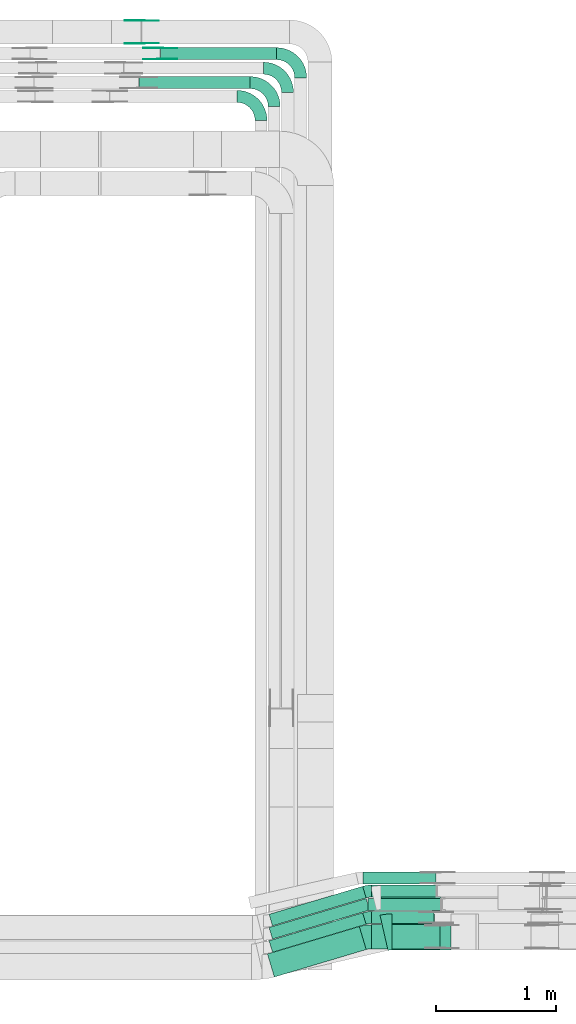
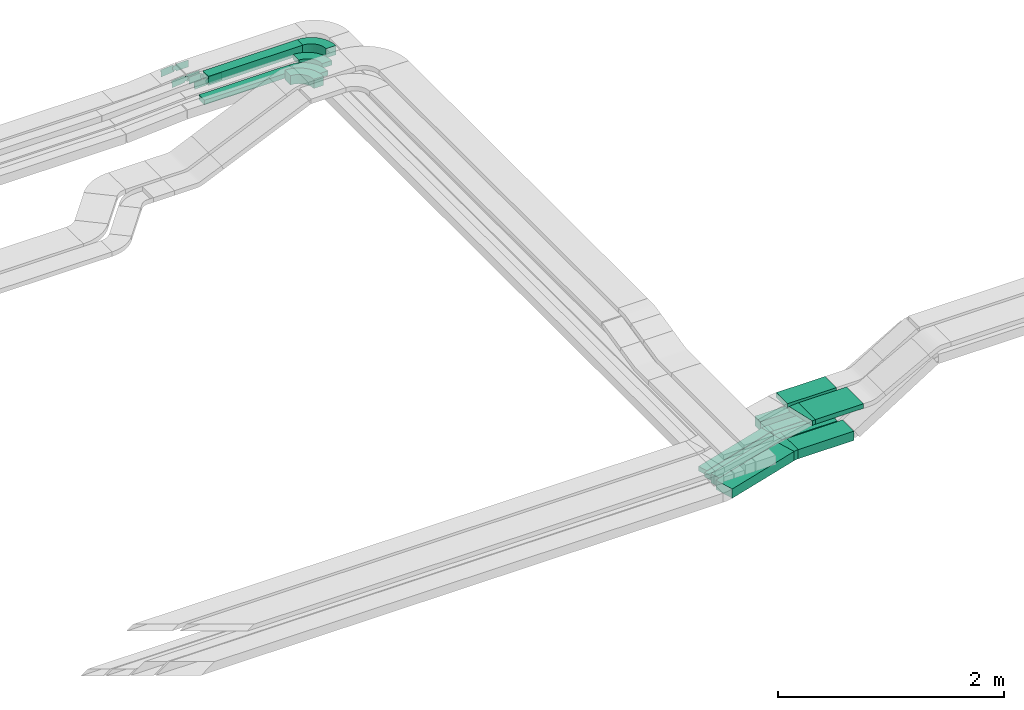
# One storey, part 24 of 31: 16 flow fittings, 13 flow segments.
"""IFC2X3 building model written with IfcOpenShell, lengths in millimetres."""

from ifc_helpers import new_model, entity, si_unit, converted_unit, derived_unit, direction, frame, frame_2d, origin, origin_2d_with_axis, place, context, subcontext, project, spatial, polyline, circle_curve, parameter, trimmed, segment, composite_curve, rectangle, outline, extrude, source, transform, mapped, material, type_object, type_shapes, element, save


model = new_model("IFC2X3")

# Units and contexts
model_context = context("Model", 3, precision=0.01, world=origin(), true_north=direction((6.12303176911189e-17, 1.0)))
body_context = subcontext(model_context, "Body", "Model", "MODEL_VIEW")
ifc_project = project(units=[si_unit("LENGTHUNIT", "METRE", prefix="MILLI"), si_unit("AREAUNIT", "SQUARE_METRE"), si_unit("VOLUMEUNIT", "CUBIC_METRE"), converted_unit("PLANEANGLEUNIT", "DEGREE", entity("IfcRatioMeasure", 0.0174532925199433), si_unit("PLANEANGLEUNIT", "RADIAN"), dimensions=[0, 0, 0, 0, 0, 0, 0]), si_unit("MASSUNIT", "GRAM", prefix="KILO"), derived_unit("MASSDENSITYUNIT", [(si_unit("MASSUNIT", "GRAM", prefix="KILO"), 1), (si_unit("LENGTHUNIT", "METRE"), -3)]), derived_unit("MOMENTOFINERTIAUNIT", [(si_unit("LENGTHUNIT", "METRE"), 4)]), si_unit("TIMEUNIT", "SECOND"), si_unit("FREQUENCYUNIT", "HERTZ"), si_unit("THERMODYNAMICTEMPERATUREUNIT", "DEGREE_CELSIUS"), derived_unit("THERMALTRANSMITTANCEUNIT", [(si_unit("MASSUNIT", "GRAM", prefix="KILO"), 1), (si_unit("THERMODYNAMICTEMPERATUREUNIT", "KELVIN"), -1), (si_unit("TIMEUNIT", "SECOND"), -3)]), derived_unit("VOLUMETRICFLOWRATEUNIT", [(si_unit("LENGTHUNIT", "METRE"), 3), (si_unit("TIMEUNIT", "SECOND"), -1)]), derived_unit("MASSFLOWRATEUNIT", [(si_unit("MASSUNIT", "GRAM", prefix="KILO"), 1), (si_unit("TIMEUNIT", "SECOND"), -1)]), derived_unit("ROTATIONALFREQUENCYUNIT", [(si_unit("TIMEUNIT", "SECOND"), -1)]), si_unit("ELECTRICCURRENTUNIT", "AMPERE"), si_unit("ELECTRICVOLTAGEUNIT", "VOLT"), si_unit("POWERUNIT", "WATT"), si_unit("FORCEUNIT", "NEWTON", prefix="KILO"), si_unit("ILLUMINANCEUNIT", "LUX"), si_unit("LUMINOUSFLUXUNIT", "LUMEN"), si_unit("LUMINOUSINTENSITYUNIT", "CANDELA"), derived_unit("USERDEFINED", [(si_unit("MASSUNIT", "GRAM", prefix="KILO"), -1), (si_unit("LENGTHUNIT", "METRE"), -2), (si_unit("TIMEUNIT", "SECOND"), 3), (si_unit("LUMINOUSFLUXUNIT", "LUMEN"), 1)]), derived_unit("LINEARVELOCITYUNIT", [(si_unit("LENGTHUNIT", "METRE"), 1), (si_unit("TIMEUNIT", "SECOND"), -1)]), si_unit("PRESSUREUNIT", "PASCAL"), derived_unit("USERDEFINED", [(si_unit("LENGTHUNIT", "METRE"), -2), (si_unit("MASSUNIT", "GRAM", prefix="KILO"), 1), (si_unit("TIMEUNIT", "SECOND"), -2)]), derived_unit("LINEARFORCEUNIT", [(si_unit("MASSUNIT", "GRAM", prefix="KILO"), 1), (si_unit("LENGTHUNIT", "METRE"), 1), (si_unit("TIMEUNIT", "SECOND"), -2), (si_unit("LENGTHUNIT", "METRE"), -1)]), derived_unit("PLANARFORCEUNIT", [(si_unit("MASSUNIT", "GRAM", prefix="KILO"), 1), (si_unit("LENGTHUNIT", "METRE"), 1), (si_unit("TIMEUNIT", "SECOND"), -2), (si_unit("LENGTHUNIT", "METRE"), -2)])], contexts=[model_context])

# Site, building, storey
site_placement = place(None, frame((0.0, -0.00077364408347762, 0.0)))
site = spatial("IfcSite", under=ifc_project, at=site_placement, CompositionType="ELEMENT")
building_placement = place(site_placement, origin())
building = spatial("IfcBuilding", under=site, at=building_placement, CompositionType="ELEMENT")
storey_placement = place(building_placement, frame((0.0, 0.0, 15900.0)))
storey = spatial("IfcBuildingStorey", under=building, at=storey_placement, CompositionType="ELEMENT", Elevation=15900.0)

# Flow segments
cable_carrier_segment_type = type_object("IfcCableCarrierSegmentType", PredefinedType="CABLETRAYSEGMENT")
flow_segment_1_placement = place(storey_placement, frame((60243.1382371041, 8665.72641574027, 2495.02366929601)))
element("IfcFlowSegment", 1, at=flow_segment_1_placement, inside=storey, type_object=cable_carrier_segment_type, context=body_context, shape_type="SweptSolid", body=[
    extrude(rectangle(XDim=812.342114695417, YDim=100.000000000006, at=frame_2d((4.14956957683899e-12, -1.23634436022257e-12), x_axis=(1.0, 0.0))), frame((403.475378060986, 164.239638386226, 0.0), z_axis=(0.0, 0.0, 1.0), x_axis=(-0.95810498938811, -0.286417229421712, 0.0)), (0.0, 0.0, 1.0), 50.0000000000016),
])
flow_segment_2_placement = place(storey_placement, frame((60243.1382371041, 8555.72641574028, 2495.0546523344)))
element("IfcFlowSegment", 2, at=flow_segment_2_placement, inside=storey, type_object=cable_carrier_segment_type, context=body_context, shape_type="SweptSolid", body=[
    extrude(rectangle(XDim=842.596647110519, YDim=100.000000000006, at=frame_2d((4.17799128626939e-12, -1.24344978758018e-12), x_axis=(1.0, 0.0))), frame((417.96888729023, 168.572348062131, 0.0), z_axis=(0.0, 0.0, 1.0), x_axis=(0.9581049893881, 0.286417229421747, 0.0)), (0.0, 0.0, 1.0), 50.0000000000016),
])
flow_segment_3_placement = place(storey_placement, frame((60243.1382371041, 8445.72641574016, 2500.0)))
element("IfcFlowSegment", 3, at=flow_segment_3_placement, inside=storey, type_object=cable_carrier_segment_type, context=body_context, shape_type="SweptSolid", body=[
    extrude(rectangle(XDim=812.342114695347, YDim=100.000000000004, at=frame_2d((1.70530256582424e-13, 5.08038056068472e-13), x_axis=(1.0, 0.0))), frame((403.475378060934, 164.239638386233, 0.0), z_axis=(0.0, 0.0, 1.0), x_axis=(-0.958104989388097, -0.286417229421757, 0.0)), (0.0, 0.0, 1.0), 99.9999999999989),
])
flow_segment_4_placement = place(storey_placement, frame((60229.5481308941, 8239.91591680136, 2500.0)))
element("IfcFlowSegment", 4, at=flow_segment_4_placement, inside=storey, type_object=cable_carrier_segment_type, context=body_context, shape_type="SweptSolid", body=[
    extrude(rectangle(XDim=797.71484848776, YDim=200.000000000007, at=frame_2d((-1.4210854715202e-13, -5.04485342389671e-13), x_axis=(1.0, 0.0))), frame((410.789011164725, 210.050137325046, 0.0), z_axis=(0.0, 0.0, 1.0), x_axis=(0.958104989388095, 0.286417229421762, 0.0)), (0.0, 0.0, 1.0), 99.9999999999989),
])
flow_segment_5_placement = place(storey_placement, frame((61095.0096826287, 8904.9658623951, 2495.02366929601)))
element("IfcFlowSegment", 5, at=flow_segment_5_placement, inside=storey, type_object=cable_carrier_segment_type, context=body_context, shape_type="SweptSolid", body=[
    extrude(rectangle(XDim=534.84490584839, YDim=99.9999999999989, at=frame_2d((-4.32009983342141e-12, -5.40012479177676e-13), x_axis=(1.0, 0.0))), frame((267.422452924191, 50.0, 0.0)), (0.0, 0.0, 1.0), 50.0000000000016),
])
flow_segment_6_placement = place(storey_placement, frame((61064.7551502134, 8794.96586239509, 2500.0)))
element("IfcFlowSegment", 6, at=flow_segment_6_placement, inside=storey, type_object=cable_carrier_segment_type, context=body_context, shape_type="SweptSolid", body=[
    extrude(rectangle(XDim=603.13391952185, YDim=100.000000000001, at=frame_2d((0.0, -5.43565192856477e-13), x_axis=(1.0, 0.0))), frame((301.566959760925, 50.0, 0.0), z_axis=(0.0, 0.0, 1.0), x_axis=(-1.0, 0.0, 0.0)), (0.0, 0.0, 1.0), 50.0000000000016),
])
flow_segment_7_placement = place(storey_placement, frame((61095.0096826286, 8684.96586239501, 2500.0)))
element("IfcFlowSegment", 7, at=flow_segment_7_placement, inside=storey, type_object=cable_carrier_segment_type, context=body_context, shape_type="SweptSolid", body=[
    extrude(rectangle(XDim=521.540062553163, YDim=99.9999999999989, at=frame_2d((0.0, 1.08357767203415e-12), x_axis=(1.0, 0.0))), frame((260.770031276573, 50.0, 0.0)), (0.0, 0.0, 1.0), 99.9999999999989),
])
flow_segment_8_placement = place(storey_placement, frame((61096.0468426262, 8474.96586239501, 2500.0)))
element("IfcFlowSegment", 8, at=flow_segment_8_placement, inside=storey, type_object=cable_carrier_segment_type, context=body_context, shape_type="SweptSolid", body=[
    extrude(rectangle(XDim=569.341253253551, YDim=200.0, at=frame_2d((4.32009983342141e-12, 0.0), x_axis=(1.0, 0.0))), frame((284.67062662678, 100.0, 0.0), z_axis=(0.0, 0.0, 1.0), x_axis=(-1.0, 0.0, 0.0)), (0.0, 0.0, 1.0), 99.9999999999989),
])
flow_segment_9_placement = place(storey_placement, frame((61174.2051072231, 8800.14842319197, 2820.0)))
element("IfcFlowSegment", 9, at=flow_segment_9_placement, inside=storey, type_object=cable_carrier_segment_type, context=body_context, shape_type="SweptSolid", body=[
    extrude(rectangle(XDim=499.125355174538, YDim=200.0, at=origin_2d_with_axis()), frame((249.562677587277, 100.0, 0.0)), (0.0, 0.0, 1.0), 50.0000000000016),
])
flow_segment_10_placement = place(storey_placement, frame((61267.5917209421, 8465.14842319196, 2820.0)))
element("IfcFlowSegment", 10, at=flow_segment_10_placement, inside=storey, type_object=cable_carrier_segment_type, context=body_context, shape_type="SweptSolid", body=[
    extrude(rectangle(XDim=489.342035058011, YDim=300.000000000001, at=frame_2d((4.33431068813661e-12, 5.40012479177676e-13), x_axis=(1.0, 0.0))), frame((244.67101752901, 150.0, 0.0)), (0.0, 0.0, 1.0), 50.0000000000016),
])
flow_segment_11_placement = place(storey_placement, frame((59341.7533007702, 15869.9939089946, 2660.0)))
element("IfcFlowSegment", 11, at=flow_segment_11_placement, inside=storey, type_object=cable_carrier_segment_type, context=body_context, shape_type="SweptSolid", body=[
    extrude(rectangle(XDim=963.323442098033, YDim=99.9999999999989, at=frame_2d((-4.32009983342141e-12, 1.08357767203415e-12), x_axis=(1.0, 0.0))), frame((481.661721049012, 50.0, 0.0), z_axis=(0.0, 0.0, 1.0), x_axis=(-1.0, 0.0, 0.0)), (0.0, 0.0, 1.0), 99.9999999999989),
])
flow_segment_12_placement = place(storey_placement, frame((59162.3763917152, 15629.4580000518, 2660.19015606754)))
element("IfcFlowSegment", 12, at=flow_segment_12_placement, inside=storey, type_object=cable_carrier_segment_type, context=body_context, shape_type="SweptSolid", body=[
    extrude(rectangle(XDim=922.700351153026, YDim=99.9999999999989, at=frame_2d((0.0, 1.08357767203415e-12), x_axis=(1.0, 0.0))), frame((461.350175576513, 50.0, 0.0), z_axis=(0.0, 0.0, 1.0), x_axis=(-1.0, 0.0, 0.0)), (0.0, 0.0, 1.0), 50.0000000000016),
])
flow_segment_13_placement = place(storey_placement, frame((61022.4340197536, 9014.96586239511, 2500.0)))
element("IfcFlowSegment", 13, at=flow_segment_13_placement, inside=storey, type_object=cable_carrier_segment_type, context=body_context, shape_type="SweptSolid", body=[
    extrude(rectangle(XDim=607.951662645595, YDim=99.9999999999989, at=frame_2d((-4.32009983342141e-12, -5.40012479177676e-13), x_axis=(1.0, 0.0))), frame((303.975831322811, 50.0, 0.0)), (0.0, 0.0, 1.0), 99.9999999999989),
])

# Flow fittings
ifc_material_1 = material()
cable_carrier_fitting_type_1 = type_object("IfcCableCarrierFittingType", Name="470_DKC_S5_Variable Angle Elbow 0-45:-", PredefinedType="NOTDEFINED", material=ifc_material_1)
shared_shape_1 = source(origin(), body_context, "Body", "SweptSolid", [
    extrude(outline(composite_curve([segment(polyline([(-29.6312491895192, -54.2611053685444), (-28.6312491895179, -54.2611053685444)]), True, "CONTINUOUS"), segment(trimmed(circle_curve(frame_2d((-28.6312491895183, 195.738894631455), x_axis=(0.0, -1.0)), 250.0), [parameter(0.0)], [parameter(16.6435818354741)], True, "PARAMETER"), True, "CONTINUOUS"), segment(polyline([(42.9730581659098, -43.7873527155719), (43.931163155298, -43.5009354861501)]), True, "CONTINUOUS"), segment(polyline([(43.931163155298, -43.5009354861502), (15.2894402131266, 52.3095634526607)]), True, "CONTINUOUS"), segment(polyline([(15.2894402131266, 52.3095634526607), (14.3313352237385, 52.023146223239)]), True, "CONTINUOUS"), segment(trimmed(circle_curve(frame_2d((-28.6312491895183, 195.738894631455), x_axis=(0.0, -1.0)), 150.0), [parameter(0.0)], [parameter(16.6435818354741)], True, "PARAMETER"), False, "CONTINUOUS"), segment(polyline([(-28.6312491895179, 45.7388946314555), (-29.6312491895192, 45.7388946314555)]), True, "CONTINUOUS"), segment(polyline([(-29.6312491895192, 45.7388946314555), (-29.6312491895192, -54.2611053685444)]), True, "CONTINUOUS")], self_intersect=False)), frame((-0.623283225632705, 4.26110536853636, -25.0)), (0.0, 0.0, 1.0), 50.0000000000001),
])
type_shapes(cable_carrier_fitting_type_1, [shared_shape_1])
flow_fitting_1_placement = place(storey_placement, frame((61064.7551502135, 8954.9658623951, 2520.02366929601), z_axis=(0.0, 0.0, 1.0), x_axis=(-1.0, 0.0, 0.0)))
element("IfcFlowFitting", 14, at=flow_fitting_1_placement, inside=storey, type_object=cable_carrier_fitting_type_1, material=ifc_material_1, Name="470_DKC_S5_Variable Angle Elbow 0-45:-", ObjectType="470_DKC_S5_Variable Angle Elbow 0-45:-", context=body_context, shape_type="MappedRepresentation", body=[
    mapped(shared_shape_1, transform((0.0, 0.0, 0.0), scale=1.0)),
])
cable_carrier_fitting_type_2 = type_object("IfcCableCarrierFittingType", Name="470_DKC_S5_Variable Angle Elbow 0-45:-", PredefinedType="NOTDEFINED", material=ifc_material_1)
shared_shape_2 = source(origin(), body_context, "Body", "SweptSolid", [
    extrude(outline(composite_curve([segment(polyline([(-29.631249189521, -54.2611053685453), (-28.6312491895196, -54.2611053685453)]), True, "CONTINUOUS"), segment(trimmed(circle_curve(frame_2d((-28.6312491895222, 195.738894631454), x_axis=(0.0, -1.0)), 250.0), [parameter(0.0)], [parameter(16.6435818354755)], True, "PARAMETER"), True, "CONTINUOUS"), segment(polyline([(42.9730581659135, -43.7873527155705), (43.9311631553015, -43.5009354861488)]), True, "CONTINUOUS"), segment(polyline([(43.9311631553016, -43.5009354861488), (15.2894402131274, 52.3095634526612)]), True, "CONTINUOUS"), segment(polyline([(15.2894402131274, 52.3095634526612), (14.3313352237392, 52.0231462232395)]), True, "CONTINUOUS"), segment(trimmed(circle_curve(frame_2d((-28.6312491895222, 195.738894631454), x_axis=(0.0, -1.0)), 150.0), [parameter(0.0)], [parameter(16.6435818354755)], True, "PARAMETER"), False, "CONTINUOUS"), segment(polyline([(-28.6312491895205, 45.7388946314545), (-29.6312491895218, 45.7388946314545)]), True, "CONTINUOUS"), segment(polyline([(-29.6312491895218, 45.7388946314545), (-29.631249189521, -54.2611053685453)]), True, "CONTINUOUS")], self_intersect=False)), frame((-0.623283225632853, 4.26110536853704, -50.0)), (0.0, 0.0, 1.0), 100.0),
])
type_shapes(cable_carrier_fitting_type_2, [shared_shape_2])
flow_fitting_2_placement = place(storey_placement, frame((61064.7551502134, 8734.96586239502, 2550.0), z_axis=(0.0, 0.0, 1.0), x_axis=(-1.0, 0.0, 0.0)))
element("IfcFlowFitting", 15, at=flow_fitting_2_placement, inside=storey, type_object=cable_carrier_fitting_type_2, material=ifc_material_1, Name="470_DKC_S5_Variable Angle Elbow 0-45:-", ObjectType="470_DKC_S5_Variable Angle Elbow 0-45:-", context=body_context, shape_type="MappedRepresentation", body=[
    mapped(shared_shape_2, transform((0.0, 0.0, 0.0), scale=1.0)),
])
cable_carrier_fitting_type_3 = type_object("IfcCableCarrierFittingType", Name="470_DKC_S5_Variable Angle Elbow 0-45:-", PredefinedType="NOTDEFINED", material=ifc_material_1)
shared_shape_3 = source(origin(), body_context, "Body", "SweptSolid", [
    extrude(outline(composite_curve([segment(polyline([(-36.7916799250648, -105.308480633842), (-35.7916799250634, -105.308480633842)]), True, "CONTINUOUS"), segment(trimmed(circle_curve(frame_2d((-35.791679925064, 244.691519366157), x_axis=(0.0, -1.0)), 350.0), [parameter(0.0)], [parameter(16.6435818354755)], True, "PARAMETER"), True, "CONTINUOUS"), segment(polyline([(64.4543503725433, -90.6452269196786), (65.4124553619312, -90.3588096902569)]), True, "CONTINUOUS"), segment(polyline([(65.4124553619312, -90.3588096902569), (8.12900947758453, 101.262188187364)]), True, "CONTINUOUS"), segment(polyline([(8.12900947758453, 101.262188187364), (7.17090448819626, 100.975770957942)]), True, "CONTINUOUS"), segment(trimmed(circle_curve(frame_2d((-35.791679925064, 244.691519366157), x_axis=(0.0, -1.0)), 150.0), [parameter(0.0)], [parameter(16.6435818354755)], True, "PARAMETER"), False, "CONTINUOUS"), segment(polyline([(-35.7916799250634, 94.6915193661574), (-36.7916799250648, 94.6915193661574)]), True, "CONTINUOUS"), segment(polyline([(-36.7916799250648, 94.6915193661574), (-36.7916799250648, -105.308480633842)]), True, "CONTINUOUS")], self_intersect=False)), frame((-0.776485593880177, 5.30848063383446, -50.0)), (0.0, 0.0, 1.0), 100.0),
])
type_shapes(cable_carrier_fitting_type_3, [shared_shape_3])
flow_fitting_3_placement = place(storey_placement, frame((61058.4786771072, 8574.96586239503, 2550.0), z_axis=(0.0, 0.0, 1.0), x_axis=(-1.0, 0.0, 0.0)))
element("IfcFlowFitting", 16, at=flow_fitting_3_placement, inside=storey, type_object=cable_carrier_fitting_type_3, material=ifc_material_1, Name="470_DKC_S5_Variable Angle Elbow 0-45:-", ObjectType="470_DKC_S5_Variable Angle Elbow 0-45:-", context=body_context, shape_type="MappedRepresentation", body=[
    mapped(shared_shape_3, transform((0.0, 0.0, 0.0), scale=1.0)),
])
cable_carrier_fitting_type_4 = type_object("IfcCableCarrierFittingType", Name="470_DKC_S5_Variable Angle Elbow 0-45:-", PredefinedType="NOTDEFINED", material=ifc_material_1)
shared_shape_4 = source(origin(), body_context, "Body", "SweptSolid", [
    extrude(outline(composite_curve([segment(polyline([(-34.2439370818879, -153.787077593141), (-33.2439370818863, -153.787077593141)]), True, "CONTINUOUS"), segment(trimmed(circle_curve(frame_2d((-33.2439370818946, 296.212922406859), x_axis=(0.0, -1.0)), 450.0), [parameter(0.0)], [parameter(12.8070045345911)], True, "PARAMETER"), True, "CONTINUOUS"), segment(polyline([(66.5065324671094, -142.5920955963), (67.4816547293384, -142.370427886191)]), True, "CONTINUOUS"), segment(polyline([(67.4816547293384, -142.370427886191), (0.98134169666951, 150.166250782582)]), True, "CONTINUOUS"), segment(polyline([(0.981341696669519, 150.166250782582), (0.00621943443999445, 149.944583072473)]), True, "CONTINUOUS"), segment(trimmed(circle_curve(frame_2d((-33.2439370818946, 296.212922406859), x_axis=(0.0, -1.0)), 150.0), [parameter(0.0)], [parameter(12.8070045345911)], True, "PARAMETER"), False, "CONTINUOUS"), segment(polyline([(-33.2439370818914, 146.212922406859), (-34.243937081893, 146.212922406859)]), True, "CONTINUOUS"), segment(polyline([(-34.243937081893, 146.212922406859), (-34.2439370818879, -153.787077593141)]), True, "CONTINUOUS")], self_intersect=False)), frame((-0.425023217098881, 3.78707759313203, -25.0)), (0.0, 0.0, 1.0), 49.9999999999996),
])
type_shapes(cable_carrier_fitting_type_4, [shared_shape_4])
flow_fitting_4_placement = place(storey_placement, frame((61232.9227606431, 8615.14842319198, 2845.0), z_axis=(0.0, 0.0, 1.0), x_axis=(-1.0, 0.0, 0.0)))
element("IfcFlowFitting", 17, at=flow_fitting_4_placement, inside=storey, type_object=cable_carrier_fitting_type_4, material=ifc_material_1, Name="470_DKC_S5_Variable Angle Elbow 0-45:-", ObjectType="470_DKC_S5_Variable Angle Elbow 0-45:-", context=body_context, shape_type="MappedRepresentation", body=[
    mapped(shared_shape_4, transform((0.0, 0.0, 0.0), scale=1.0)),
])
cable_carrier_fitting_type_5 = type_object("IfcCableCarrierFittingType", Name="470_DKC_S5_Variable Angle Elbow 0-45:-", PredefinedType="NOTDEFINED", material=ifc_material_1)
shared_shape_5 = source(origin(), body_context, "Body", "SweptSolid", [
    extrude(outline(composite_curve([segment(polyline([(-100.749999999999, -150.250000000001), (-99.7499999999981, -150.250000000001)]), True, "CONTINUOUS"), segment(trimmed(circle_curve(frame_2d((-99.7500000000006, 99.7499999999987), x_axis=(0.0, -1.0)), 250.0), [parameter(0.0)], [parameter(90.0000000000001)], True, "PARAMETER"), True, "CONTINUOUS"), segment(polyline([(150.249999999999, 99.7500000000013), (150.249999999999, 100.750000000001)]), True, "CONTINUOUS"), segment(polyline([(150.249999999999, 100.750000000001), (50.2499999999992, 100.750000000001)]), True, "CONTINUOUS"), segment(polyline([(50.2499999999992, 100.750000000001), (50.2499999999992, 99.7500000000002)]), True, "CONTINUOUS"), segment(trimmed(circle_curve(frame_2d((-99.7500000000006, 99.7499999999987), x_axis=(0.0, -1.0)), 150.0), [parameter(0.0)], [parameter(90.0000000000001)], True, "PARAMETER"), False, "CONTINUOUS"), segment(polyline([(-99.7499999999989, -50.2500000000011), (-100.75, -50.2500000000011)]), True, "CONTINUOUS"), segment(polyline([(-100.75, -50.2500000000011), (-100.749999999999, -150.250000000001)]), True, "CONTINUOUS")], self_intersect=False)), frame((-100.249999999991, 100.249999999992, -50.0)), (0.0, 0.0, 1.0), 100.0),
])
type_shapes(cable_carrier_fitting_type_5, [shared_shape_5])
for number, where, z_axis, x_axis, name in (
    (18, (60506.0767428682, 15919.9939089946, 2710.0), (0.0, 0.0, 1.0), (0.0, 1.0, 0.0), "470_DKC_S5_Variable Angle Elbow 0-45:-"),
    (19, (60176.0767428682, 15564.9939089946, 2710.0), (0.0, 0.0, 1.0), (0.0, 1.0, 0.0), "470_DKC_S5_Variable Angle Elbow 0-45:-"),
):
    element("IfcFlowFitting", number, at=place(storey_placement, frame(where, z_axis=z_axis, x_axis=x_axis)), inside=storey, type_object=cable_carrier_fitting_type_5, material=ifc_material_1, Name=name, ObjectType="470_DKC_S5_Variable Angle Elbow 0-45:-", context=body_context, shape_type="MappedRepresentation", body=[
        mapped(shared_shape_5, transform((0.0, 0.0, 0.0), scale=1.0)),
    ])
cable_carrier_fitting_type_6 = type_object("IfcCableCarrierFittingType", Name="470_DKC_S5_Variable Angle Elbow 0-45:-", PredefinedType="NOTDEFINED", material=ifc_material_1)
shared_shape_6 = source(origin(), body_context, "Body", "SweptSolid", [
    extrude(outline(composite_curve([segment(polyline([(-100.750000000001, -150.25), (-99.7499999999994, -150.25)]), True, "CONTINUOUS"), segment(trimmed(circle_curve(frame_2d((-99.7499999999997, 99.7499999999995), x_axis=(0.0, -1.0)), 250.0), [parameter(0.0)], [parameter(90.0000000000001)], True, "PARAMETER"), True, "CONTINUOUS"), segment(polyline([(150.25, 99.75), (150.25, 100.749999999999)]), True, "CONTINUOUS"), segment(polyline([(150.25, 100.749999999999), (50.25, 100.75)]), True, "CONTINUOUS"), segment(polyline([(50.25, 100.75), (50.25, 99.7499999999998)]), True, "CONTINUOUS"), segment(trimmed(circle_curve(frame_2d((-99.7499999999997, 99.7499999999995), x_axis=(0.0, -1.0)), 150.0), [parameter(0.0)], [parameter(90.0000000000001)], True, "PARAMETER"), False, "CONTINUOUS"), segment(polyline([(-99.7499999999994, -50.2500000000003), (-100.750000000001, -50.2500000000003)]), True, "CONTINUOUS"), segment(polyline([(-100.750000000001, -50.2500000000003), (-100.750000000001, -150.25)]), True, "CONTINUOUS")], self_intersect=False)), frame((-100.249999999991, 100.249999999992, -25.0)), (0.0, 0.0, 1.0), 49.9999999999997),
])
type_shapes(cable_carrier_fitting_type_6, [shared_shape_6])
for number, where, z_axis, x_axis, name in (
    (20, (60396.0767428682, 15799.4580000518, 2685.19508428161), (0.0, 0.0, 1.0), (0.0, 1.0, 0.0), "470_DKC_S5_Variable Angle Elbow 0-45:-"),
    (21, (60286.0767428682, 15679.4580000518, 2685.19015606755), (0.0, 0.0, 1.0), (0.0, 1.0, 0.0), "470_DKC_S5_Variable Angle Elbow 0-45:-"),
):
    element("IfcFlowFitting", number, at=place(storey_placement, frame(where, z_axis=z_axis, x_axis=x_axis)), inside=storey, type_object=cable_carrier_fitting_type_6, material=ifc_material_1, Name=name, ObjectType="470_DKC_S5_Variable Angle Elbow 0-45:-", context=body_context, shape_type="MappedRepresentation", body=[
        mapped(shared_shape_6, transform((0.0, 0.0, 0.0), scale=1.0)),
    ])
ifc_material_2 = material(Name="G")
cable_carrier_fitting_type_7 = type_object("IfcCableCarrierFittingType", PredefinedType="NOTDEFINED", material=ifc_material_2)
shared_shape_7 = source(origin(), body_context, "Body", "SweptSolid", [
    extrude(outline(composite_curve([segment(trimmed(circle_curve(frame_2d((-41.4651162790697, 0.0), x_axis=(1.0, 0.0)), 25.0), [parameter(90.0000000000007)], [parameter(270.0)], True, "PARAMETER"), True, "CONTINUOUS"), segment(polyline([(-41.4651162790697, -25.0), (-29.9651162790697, -25.0)]), True, "CONTINUOUS"), segment(polyline([(-29.9651162790697, -25.0), (-28.1046511627907, -38.5)]), True, "CONTINUOUS"), segment(polyline([(-28.1046511627907, -38.5), (99.5348837209303, -38.5)]), True, "CONTINUOUS"), segment(polyline([(99.5348837209303, -38.5), (99.5348837209303, 38.5)]), True, "CONTINUOUS"), segment(polyline([(99.5348837209303, 38.5), (-28.1046511627907, 38.5)]), True, "CONTINUOUS"), segment(polyline([(-28.1046511627907, 38.5), (-29.9651162790697, 25.0)]), True, "CONTINUOUS"), segment(polyline([(-29.9651162790697, 25.0), (-41.46511627907, 25.0)]), True, "CONTINUOUS")], self_intersect=False)), frame((41.4651162790697, 0.0, 0.0), z_axis=(0.0, 0.0, -1.0), x_axis=(1.0, 0.0, 0.0)), (0.0, 0.0, -1.0), 2.0),
])
type_shapes(cable_carrier_fitting_type_7, [shared_shape_7])
for number, where, z_axis, x_axis in (
    (22, (59339.6352808, 15874.5339089845, 2710.0), (0.0, -1.0, 0.0), (-0.999143050018218, 0.0, -0.0413904046886741)),
    (23, (59186.076742868, 16004.5339089844, 2710.0), (0.0, -1.0, 0.0), (-0.995891337468728, 0.0, -0.0905563026782111)),
):
    element("IfcFlowFitting", number, at=place(storey_placement, frame(where, z_axis=z_axis, x_axis=x_axis)), inside=storey, type_object=cable_carrier_fitting_type_7, material=ifc_material_2, context=body_context, shape_type="MappedRepresentation", body=[
        mapped(shared_shape_7, transform((0.0, 0.0, 0.0), scale=1.0)),
    ])
cable_carrier_fitting_type_8 = type_object("IfcCableCarrierFittingType", PredefinedType="NOTDEFINED", material=ifc_material_2)
shared_shape_8 = source(origin(), body_context, "Body", "SweptSolid", [
    extrude(outline(composite_curve([segment(trimmed(circle_curve(frame_2d((-41.4651162790697, 0.0), x_axis=(1.0, 0.0)), 25.0), [parameter(90.0000000000007)], [parameter(270.0)], True, "PARAMETER"), True, "CONTINUOUS"), segment(polyline([(-41.4651162790697, -25.0), (-29.9651162790697, -25.0)]), True, "CONTINUOUS"), segment(polyline([(-29.9651162790697, -25.0), (-28.1046511627907, -38.5)]), True, "CONTINUOUS"), segment(polyline([(-28.1046511627907, -38.5), (99.5348837209303, -38.5)]), True, "CONTINUOUS"), segment(polyline([(99.5348837209303, -38.5), (99.5348837209303, 38.5)]), True, "CONTINUOUS"), segment(polyline([(99.5348837209303, 38.5), (-28.1046511627907, 38.5)]), True, "CONTINUOUS"), segment(polyline([(-28.1046511627907, 38.5), (-29.9651162790697, 25.0)]), True, "CONTINUOUS"), segment(polyline([(-29.9651162790697, 25.0), (-41.46511627907, 25.0)]), True, "CONTINUOUS")], self_intersect=False)), frame((41.4651162790697, 0.0, 0.0)), (0.0, 0.0, 1.0), 2.0),
])
type_shapes(cable_carrier_fitting_type_8, [shared_shape_8])
for number, where, z_axis, x_axis in (
    (24, (59339.6352808, 15965.4539090048, 2710.0), (0.0, 1.0, 0.0), (-0.999143050018218, 0.0, -0.0413904046886741)),
    (25, (59186.076742868, 16195.4539090048, 2710.0), (0.0, 1.0, 0.0), (-0.995891337468728, 0.0, -0.0905563026782111)),
):
    element("IfcFlowFitting", number, at=place(storey_placement, frame(where, z_axis=z_axis, x_axis=x_axis)), inside=storey, type_object=cable_carrier_fitting_type_8, material=ifc_material_2, context=body_context, shape_type="MappedRepresentation", body=[
        mapped(shared_shape_8, transform((0.0, 0.0, 0.0), scale=1.0)),
    ])
cable_carrier_fitting_type_9 = type_object("IfcCableCarrierFittingType", PredefinedType="NOTDEFINED", material=ifc_material_2)
shared_shape_9 = source(origin(), body_context, "Body", "SweptSolid", [
    extrude(outline(composite_curve([segment(trimmed(circle_curve(frame_2d((-41.4651162790697, 0.0), x_axis=(1.0, 0.0)), 25.0), [parameter(90.0000000000007)], [parameter(270.0)], True, "PARAMETER"), True, "CONTINUOUS"), segment(polyline([(-41.4651162790697, -25.0), (-29.9651162790697, -25.0)]), True, "CONTINUOUS"), segment(polyline([(-29.9651162790697, -25.0), (-28.1046511627907, -38.5)]), True, "CONTINUOUS"), segment(polyline([(-28.1046511627907, -38.5), (99.5348837209303, -38.5)]), True, "CONTINUOUS"), segment(polyline([(99.5348837209303, -38.5), (99.5348837209303, 38.5)]), True, "CONTINUOUS"), segment(polyline([(99.5348837209303, 38.5), (-28.1046511627907, 38.5)]), True, "CONTINUOUS"), segment(polyline([(-28.1046511627907, 38.5), (-29.9651162790697, 25.0)]), True, "CONTINUOUS"), segment(polyline([(-29.9651162790697, 25.0), (-41.46511627907, 25.0)]), True, "CONTINUOUS")], self_intersect=False)), frame((41.4651162790697, 0.0, 0.0), z_axis=(0.0, 0.0, -1.0), x_axis=(1.0, 0.0, 0.0)), (0.0, 0.0, -1.0), 2.0),
])
type_shapes(cable_carrier_fitting_type_9, [shared_shape_9])
for number, where, z_axis, x_axis in (
    (26, (59339.6352808, 15963.4539090048, 2710.0), (0.0, 1.0, 0.0), (1.0, 0.0, 0.0)),
    (27, (59186.076742868, 16193.4539090048, 2710.0), (0.0, 1.0, 0.0), (1.0, 0.0, 0.0)),
):
    element("IfcFlowFitting", number, at=place(storey_placement, frame(where, z_axis=z_axis, x_axis=x_axis)), inside=storey, type_object=cable_carrier_fitting_type_9, material=ifc_material_2, context=body_context, shape_type="MappedRepresentation", body=[
        mapped(shared_shape_9, transform((0.0, 0.0, 0.0), scale=1.0)),
    ])
cable_carrier_fitting_type_10 = type_object("IfcCableCarrierFittingType", PredefinedType="NOTDEFINED", material=ifc_material_2)
shared_shape_10 = source(origin(), body_context, "Body", "SweptSolid", [
    extrude(outline(composite_curve([segment(trimmed(circle_curve(frame_2d((-41.4651162790697, 0.0), x_axis=(1.0, 0.0)), 25.0), [parameter(90.0000000000007)], [parameter(270.0)], True, "PARAMETER"), True, "CONTINUOUS"), segment(polyline([(-41.4651162790697, -25.0), (-29.9651162790697, -25.0)]), True, "CONTINUOUS"), segment(polyline([(-29.9651162790697, -25.0), (-28.1046511627907, -38.5)]), True, "CONTINUOUS"), segment(polyline([(-28.1046511627907, -38.5), (99.5348837209303, -38.5)]), True, "CONTINUOUS"), segment(polyline([(99.5348837209303, -38.5), (99.5348837209303, 38.5)]), True, "CONTINUOUS"), segment(polyline([(99.5348837209303, 38.5), (-28.1046511627907, 38.5)]), True, "CONTINUOUS"), segment(polyline([(-28.1046511627907, 38.5), (-29.9651162790697, 25.0)]), True, "CONTINUOUS"), segment(polyline([(-29.9651162790697, 25.0), (-41.46511627907, 25.0)]), True, "CONTINUOUS")], self_intersect=False)), frame((41.4651162790697, 0.0, 0.0)), (0.0, 0.0, 1.0), 2.0),
])
type_shapes(cable_carrier_fitting_type_10, [shared_shape_10])
for number, where, z_axis, x_axis in (
    (28, (59339.6352808, 15876.5339089845, 2710.0), (0.0, -1.0, 0.0), (1.0, 0.0, 0.0)),
    (29, (59186.076742868, 16006.5339089844, 2710.0), (0.0, -1.0, 0.0), (1.0, 0.0, 0.0)),
):
    element("IfcFlowFitting", number, at=place(storey_placement, frame(where, z_axis=z_axis, x_axis=x_axis)), inside=storey, type_object=cable_carrier_fitting_type_10, material=ifc_material_2, context=body_context, shape_type="MappedRepresentation", body=[
        mapped(shared_shape_10, transform((0.0, 0.0, 0.0), scale=1.0)),
    ])

save(model, "model.ifc")
